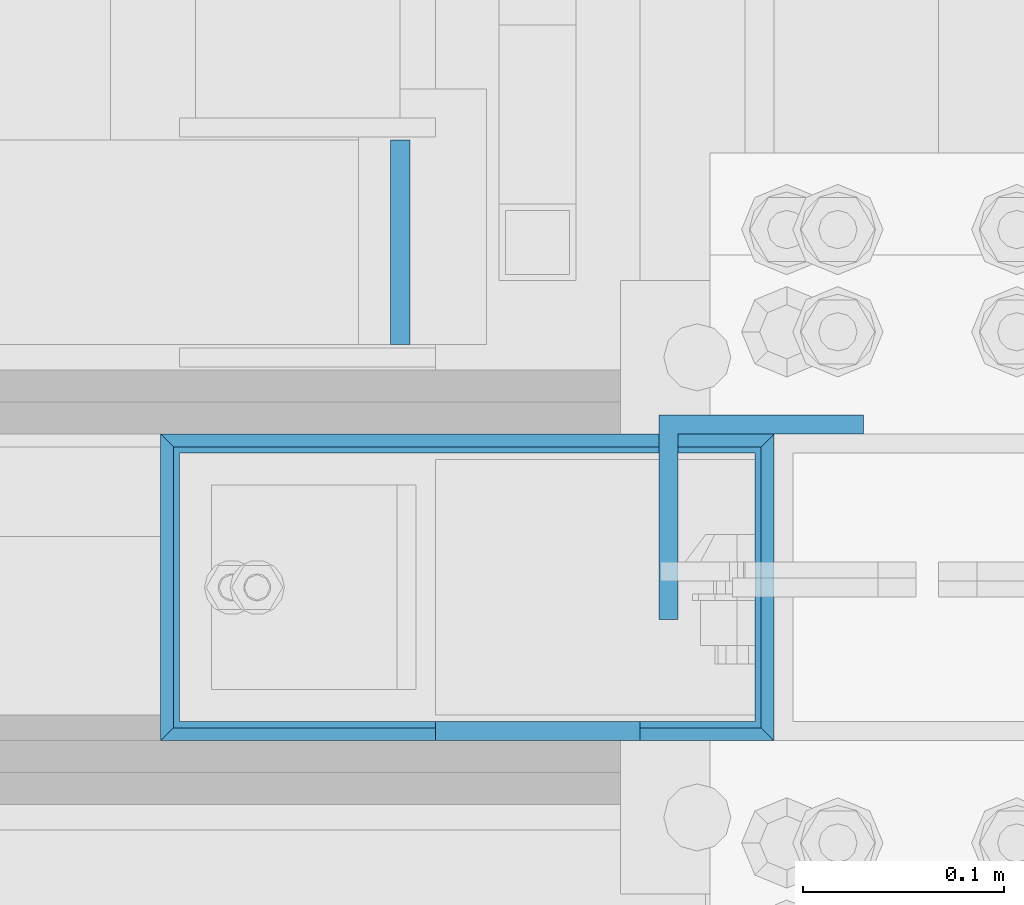
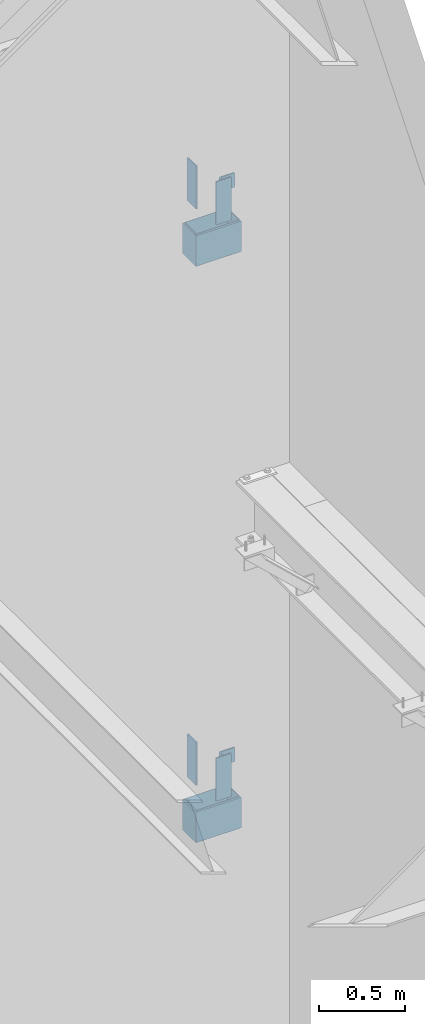
# One storey, part 572 of 1179: 8 columns, 7 elements without a shape of their own.
"""IFC2X3 building model written with IfcOpenShell, lengths in millimetres."""

from ifc_helpers import new_model, si_unit, frame, origin_with_axes, place, context, subcontext, project, spatial, faceted_brep, material, type_object, element, aggregate, save


model = new_model("IFC2X3")

# Units and contexts
model_context = context("Model", 3, precision=1e-05, world=origin_with_axes())
body_context = subcontext(model_context, "Body", "Model", "MODEL_VIEW")
ifc_project = project(units=[si_unit("LENGTHUNIT", "METRE", prefix="MILLI"), si_unit("AREAUNIT", "SQUARE_METRE"), si_unit("VOLUMEUNIT", "CUBIC_METRE"), si_unit("MASSUNIT", "GRAM", prefix="KILO"), si_unit("TIMEUNIT", "SECOND"), si_unit("PLANEANGLEUNIT", "RADIAN"), si_unit("SOLIDANGLEUNIT", "STERADIAN"), si_unit("THERMODYNAMICTEMPERATUREUNIT", "DEGREE_CELSIUS"), si_unit("LUMINOUSINTENSITYUNIT", "LUMEN")], contexts=[model_context])

# Site, building, storey
site_placement = place(None, origin_with_axes())
site = spatial("IfcSite", under=ifc_project, at=site_placement, CompositionType="ELEMENT")
building_placement = place(site_placement, origin_with_axes())
building = spatial("IfcBuilding", under=site, at=building_placement, Name="Undefined", CompositionType="ELEMENT")
storey_placement = place(building_placement, origin_with_axes())
storey = spatial("IfcBuildingStorey", under=building, at=storey_placement, Name="Undefined", CompositionType="ELEMENT", Elevation=0.0)

# Assembly, column
assembly_1_placement = place(storey_placement, origin_with_axes())
assembly_1 = element("IfcElementAssembly", 1, at=assembly_1_placement, inside=storey, Name="STAIR", AssemblyPlace="NOTDEFINED", PredefinedType="RIGID_FRAME")
ifc_material_1 = material(Name="STEEL/A36")
column_type_1 = type_object("IfcColumnType", PredefinedType="NOTDEFINED")
column_1_placement = place(assembly_1_placement, frame((24045.8625, 38157.1499999749, 5937.25000000013), z_axis=(0.0, 1.0, 0.0), x_axis=(0.0, 0.0, 1.0)))
column_1 = element("IfcColumn", 2, at=column_1_placement, type_object=column_type_1, material=ifc_material_1, Name="PLATE", context=body_context, shape_type="Brep", body=[
    faceted_brep([(0.0, 4.76249999999982, -50.7999999999993), (0.0, 4.76249999999982, 50.7999999999993), (304.799999999999, 4.76249999999709, 50.8), (304.799999999999, 4.76249999999709, -50.8), (0.0, -4.76249999999982, 50.7999999999993), (304.799999999999, -4.76249999999709, 50.8), (0.0, -4.76249999999982, -50.7999999999993), (304.799999999999, -4.76249999999709, -50.8)], [[[0, 1, 2, 3]], [[1, 4, 5, 2]], [[4, 6, 7, 5]], [[6, 0, 3, 7]], [[5, 7, 3, 2]], [[6, 4, 1, 0]]]),
])
aggregate(assembly_1, [column_1])

assembly_2_placement = place(storey_placement, origin_with_axes())
assembly_2 = element("IfcElementAssembly", 3, at=assembly_2_placement, inside=storey, Name="BEAM", AssemblyPlace="NOTDEFINED", PredefinedType="RIGID_FRAME")
column_2_placement = place(assembly_2_placement, frame((24114.125, 37914.2625, 5937.25), z_axis=(1.0, 0.0, 0.0), x_axis=(0.0, 0.0, 1.0)))
column_2 = element("IfcColumn", 4, at=column_2_placement, type_object=column_type_1, material=ifc_material_1, Name="PLATE", context=body_context, shape_type="Brep", body=[
    faceted_brep([(0.0, 4.76249999999982, -50.7999999999993), (0.0, 4.76249999999982, 50.7999999999993), (304.799999999999, 4.76249999999709, 50.8), (304.799999999999, 4.76249999999709, -50.8), (0.0, -4.76249999999982, 50.7999999999993), (304.799999999999, -4.76249999999709, 50.8), (0.0, -4.76249999999982, -50.7999999999993), (304.799999999999, -4.76249999999709, -50.8)], [[[0, 1, 2, 3]], [[1, 4, 5, 2]], [[4, 6, 7, 5]], [[6, 0, 3, 7]], [[5, 7, 3, 2]], [[6, 4, 1, 0]]]),
])
aggregate(assembly_2, [column_2])

assembly_3_placement = place(storey_placement, origin_with_axes())
assembly_3 = element("IfcElementAssembly", 5, at=assembly_3_placement, inside=storey, Name="STAIR", AssemblyPlace="NOTDEFINED", PredefinedType="RIGID_FRAME")
column_3_placement = place(assembly_3_placement, frame((24045.8625004143, 38157.1499999749, 1851.02499935032), z_axis=(0.0, 1.0, 0.0), x_axis=(0.0, 0.0, 1.0)))
column_3 = element("IfcColumn", 6, at=column_3_placement, type_object=column_type_1, material=ifc_material_1, Name="PLATE", context=body_context, shape_type="Brep", body=[
    faceted_brep([(0.0, 4.76249999999982, -50.7999999999993), (0.0, 4.76249999999982, 50.7999999999993), (304.799999999999, 4.76249999999709, 50.8), (304.799999999999, 4.76249999999709, -50.8), (0.0, -4.76249999999982, 50.7999999999993), (304.799999999999, -4.76249999999709, 50.8), (0.0, -4.76249999999982, -50.7999999999993), (304.799999999999, -4.76249999999709, -50.8)], [[[0, 1, 2, 3]], [[1, 4, 5, 2]], [[4, 6, 7, 5]], [[6, 0, 3, 7]], [[5, 7, 3, 2]], [[6, 4, 1, 0]]]),
])
aggregate(assembly_3, [column_3])

assembly_4_placement = place(storey_placement, origin_with_axes())
assembly_4 = element("IfcElementAssembly", 7, at=assembly_4_placement, inside=storey, Name="BEAM", AssemblyPlace="NOTDEFINED", PredefinedType="RIGID_FRAME")
column_4_placement = place(assembly_4_placement, frame((24114.1250004143, 37914.2625, 1851.025), z_axis=(1.0, 0.0, 0.0), x_axis=(0.0, 0.0, 1.0)))
column_4 = element("IfcColumn", 8, at=column_4_placement, type_object=column_type_1, material=ifc_material_1, Name="PLATE", context=body_context, shape_type="Brep", body=[
    faceted_brep([(0.0, 4.76249999999982, -50.7999999999993), (0.0, 4.76249999999982, 50.7999999999993), (304.799999999999, 4.76249999999709, 50.8), (304.799999999999, 4.76249999999709, -50.8), (0.0, -4.76249999999982, 50.7999999999993), (304.799999999999, -4.76249999999709, 50.8), (0.0, -4.76249999999982, -50.7999999999993), (304.799999999999, -4.76249999999709, -50.8)], [[[0, 1, 2, 3]], [[1, 4, 5, 2]], [[4, 6, 7, 5]], [[6, 0, 3, 7]], [[5, 7, 3, 2]], [[6, 4, 1, 0]]]),
])
aggregate(assembly_4, [column_4])

assembly_5_placement = place(storey_placement, origin_with_axes())
assembly_5 = element("IfcElementAssembly", 9, at=assembly_5_placement, inside=storey, Name="COLUMN", AssemblyPlace="NOTDEFINED", PredefinedType="RIGID_FRAME")
column_type_2 = type_object("IfcColumnType", Name="L4X4X3/8", PredefinedType="NOTDEFINED")
column_5_placement = place(assembly_5_placement, frame((24225.25, 38020.625, 6038.85), z_axis=(0.0, -1.0, 0.0), x_axis=(0.0, 0.0, 1.0)))
column_5 = element("IfcColumn", 10, at=column_5_placement, type_object=column_type_2, material=ifc_material_1, Name="ANGLE", ObjectType="L4X4X3/8", context=body_context, shape_type="Brep", body=[
    faceted_brep([(1.90993887372315e-11, 50.8000000000002, -50.8000000000002), (1.90993887372315e-11, 50.8000000000002, 50.8000000000002), (101.599999999991, 50.7999999999993, 50.8000000000029), (101.599999999991, 50.7999999999993, -50.8000000000029), (0.0, 41.2750000000015, 50.8000000000029), (101.599999999991, 41.2750000000015, 50.8000000000029), (0.0, 41.2750000000015, -41.2750000000015), (101.599999999991, 41.2750000000015, -41.2750000000015), (0.0, -50.7999999999993, -41.2750000000015), (101.599999999991, -50.7999999999993, -41.2750000000015), (-1.81898940354586e-11, -50.7999999999997, -50.8000000000002), (101.599999999991, -50.7999999999993, -50.8000000000029)], [[[0, 1, 2, 3]], [[1, 4, 5, 2]], [[4, 6, 7, 5]], [[6, 8, 9, 7]], [[8, 10, 11, 9]], [[10, 0, 3, 11]], [[5, 7, 9, 11, 3, 2]], [[10, 8, 6, 4, 1, 0]]]),
])

assembly_6_placement = place(storey_placement, origin_with_axes())
assembly_6 = element("IfcElementAssembly", 11, at=assembly_6_placement, inside=storey, Name="COLUMN", AssemblyPlace="NOTDEFINED", PredefinedType="RIGID_FRAME")
column_6_placement = place(assembly_6_placement, frame((24225.2500004143, 38020.625, 1965.325), z_axis=(0.0, -1.0, 0.0), x_axis=(0.0, 0.0, 1.0)))
column_6 = element("IfcColumn", 12, at=column_6_placement, type_object=column_type_2, material=ifc_material_1, Name="ANGLE", ObjectType="L4X4X3/8", context=body_context, shape_type="Brep", body=[
    faceted_brep([(1.90993887372315e-11, 50.8000000000002, -50.8000000000002), (1.90993887372315e-11, 50.8000000000002, 50.8000000000002), (101.599999999991, 50.7999999999993, 50.8000000000029), (101.599999999991, 50.7999999999993, -50.8000000000029), (0.0, 41.2750000000015, 50.8000000000029), (101.599999999991, 41.2750000000015, 50.8000000000029), (0.0, 41.2750000000015, -41.2750000000015), (101.599999999991, 41.2750000000015, -41.2750000000015), (0.0, -50.7999999999993, -41.2750000000015), (101.599999999991, -50.7999999999993, -41.2750000000015), (-1.81898940354586e-11, -50.7999999999997, -50.8000000000002), (101.599999999991, -50.7999999999993, -50.8000000000029)], [[[0, 1, 2, 3]], [[1, 4, 5, 2]], [[4, 6, 7, 5]], [[6, 8, 9, 7]], [[8, 10, 11, 9]], [[10, 0, 3, 11]], [[5, 7, 9, 11, 3, 2]], [[10, 8, 6, 4, 1, 0]]]),
])
aggregate(assembly_6, [column_6])

# Column
ifc_material_2 = material()
column_type_3 = type_object("IfcColumnType", Name="HSS12X6X3/8", PredefinedType="NOTDEFINED")
column_7_placement = place(assembly_5_placement, frame((24079.1999999167, 37985.7, 5672.13749960652), z_axis=(-1.0, 0.0, 0.0), x_axis=(0.0, 0.0, 1.0)))
column_7 = element("IfcColumn", 13, at=column_7_placement, type_object=column_type_3, material=ifc_material_2, Name="COLUMN", ObjectType="HSS12X6X3/8", context=body_context, shape_type="Brep", body=[
    faceted_brep([(19.0500000068159, 76.1999999999971, 152.399999999983), (19.0500000008351, 76.1999999999971, -152.400000000016), (12.7000000006929, 69.8499999998676, -146.049999999876), (12.7000000004273, 69.8499999976411, 146.049999995135), (19.0500000008351, -76.1999999999971, -152.400000000016), (12.7000000006929, -69.8499999998676, -146.049999999876), (19.0500000024613, -76.2000000021799, 152.400000002155), (12.7000000004273, -69.8499999976411, 146.049999995135), (12.7000000006901, -66.6750000000029, -142.875000000011), (12.70000000043, -66.6750000000029, 142.874999999989), (241.300000000429, -66.6750000000029, 142.874999999785), (241.300000000689, -66.6750000000029, -142.875000000215), (12.70000000043, 66.6750000000029, 142.874999999989), (241.300000000429, 66.6750000000029, 142.874999999785), (12.7000000006901, 66.6750000000029, -142.875000000011), (241.300000000689, 66.6750000000029, -142.875000000215), (241.300000000426, 69.8500000023487, 146.05000000463), (234.950000006806, 76.1999999999971, 152.39999999979), (234.950000006806, -76.1999999999971, 152.39999999979), (241.299999997931, -69.8500000023632, 146.050000002135), (234.95000000084, -76.1999999999971, -152.400000000209), (234.950000000833, 76.1999999999971, -152.400000000209), (241.300000000691, 69.8500000001295, -146.050000000356), (241.300000000691, -69.8500000001441, -146.050000000356)], [[[0, 1, 2, 3]], [[4, 5, 2, 1]], [[6, 7, 5, 4]], [[8, 9, 10, 11]], [[9, 12, 13, 10]], [[12, 14, 15, 13]], [[16, 17, 18, 19]], [[18, 17, 0, 6]], [[20, 18, 6, 4]], [[21, 20, 4, 1]], [[17, 21, 1, 0]], [[16, 22, 21, 17]], [[23, 20, 21, 22]], [[19, 18, 20, 23]], [[22, 16, 19, 23], [10, 13, 15, 11]], [[14, 8, 11, 15]], [[3, 2, 5, 7], [12, 9, 8, 14]], [[0, 3, 7, 6]]]),
])

aggregate(assembly_5, [column_5, column_7])

# Assembly, column
assembly_7_placement = place(storey_placement, origin_with_axes())
assembly_7 = element("IfcElementAssembly", 14, at=assembly_7_placement, inside=storey, Name="COLUMN", AssemblyPlace="NOTDEFINED", PredefinedType="RIGID_FRAME")
column_8_placement = place(assembly_7_placement, frame((24079.1999999167, 37985.7, 1585.91249936011), z_axis=(-1.0, 0.0, 0.0), x_axis=(0.0, 0.0, 1.0)))
column_8 = element("IfcColumn", 15, at=column_8_placement, type_object=column_type_3, material=ifc_material_2, Name="COLUMN", ObjectType="HSS12X6X3/8", context=body_context, shape_type="Brep", body=[
    faceted_brep([(19.0500000068159, 76.1999999999971, 152.399999999983), (19.0500000008351, 76.1999999999971, -152.400000000016), (12.7000000006929, 69.8499999998676, -146.049999999876), (12.7000000004273, 69.8499999976411, 146.049999995135), (19.0500000008351, -76.1999999999971, -152.400000000016), (12.7000000006929, -69.8499999998676, -146.049999999876), (19.0500000024613, -76.2000000021799, 152.400000002155), (12.7000000004273, -69.8499999976411, 146.049999995135), (12.7000000006901, -66.6750000000029, -142.875000000011), (12.70000000043, -66.6750000000029, 142.874999999989), (241.300000000429, -66.6750000000029, 142.874999999785), (241.300000000689, -66.6750000000029, -142.875000000215), (12.70000000043, 66.6750000000029, 142.874999999989), (241.300000000429, 66.6750000000029, 142.874999999785), (12.7000000006901, 66.6750000000029, -142.875000000011), (241.300000000689, 66.6750000000029, -142.875000000215), (241.300000000426, 69.8500000023487, 146.05000000463), (234.950000006806, 76.1999999999971, 152.39999999979), (234.950000006806, -76.1999999999971, 152.39999999979), (241.299999997931, -69.8500000023632, 146.050000002135), (234.95000000084, -76.1999999999971, -152.400000000209), (234.950000000833, 76.1999999999971, -152.400000000209), (241.300000000691, 69.8500000001295, -146.050000000356), (241.300000000691, -69.8500000001441, -146.050000000356)], [[[0, 1, 2, 3]], [[4, 5, 2, 1]], [[6, 7, 5, 4]], [[8, 9, 10, 11]], [[9, 12, 13, 10]], [[12, 14, 15, 13]], [[16, 17, 18, 19]], [[18, 17, 0, 6]], [[20, 18, 6, 4]], [[21, 20, 4, 1]], [[17, 21, 1, 0]], [[16, 22, 21, 17]], [[23, 20, 21, 22]], [[19, 18, 20, 23]], [[22, 16, 19, 23], [10, 13, 15, 11]], [[14, 8, 11, 15]], [[3, 2, 5, 7], [12, 9, 8, 14]], [[0, 3, 7, 6]]]),
])
aggregate(assembly_7, [column_8])

save(model, "model.ifc")
